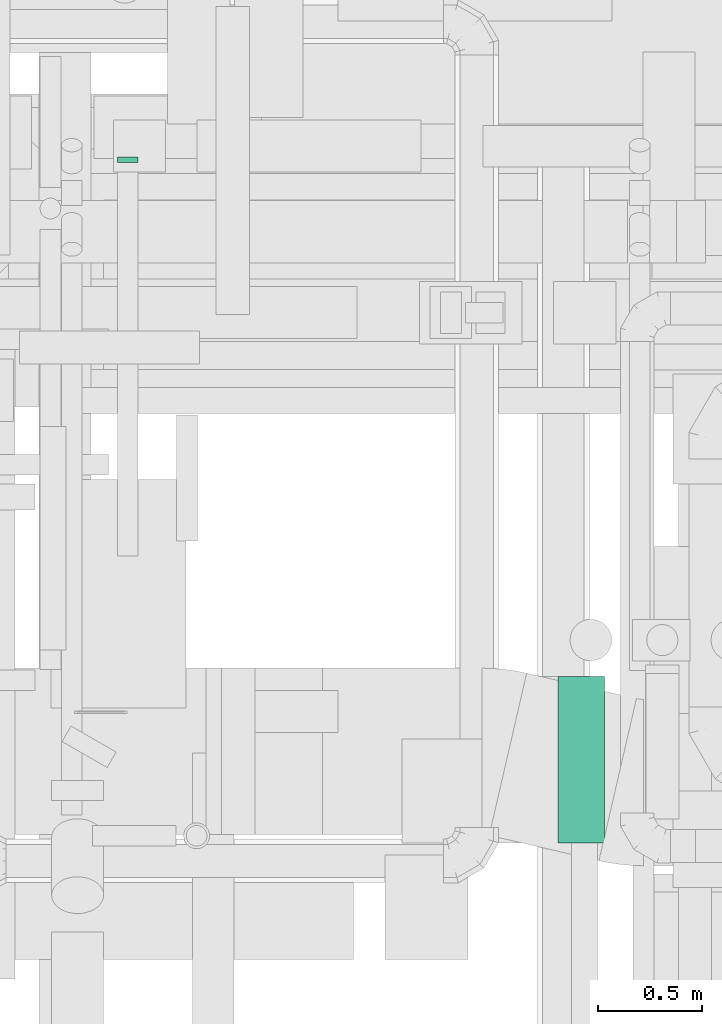
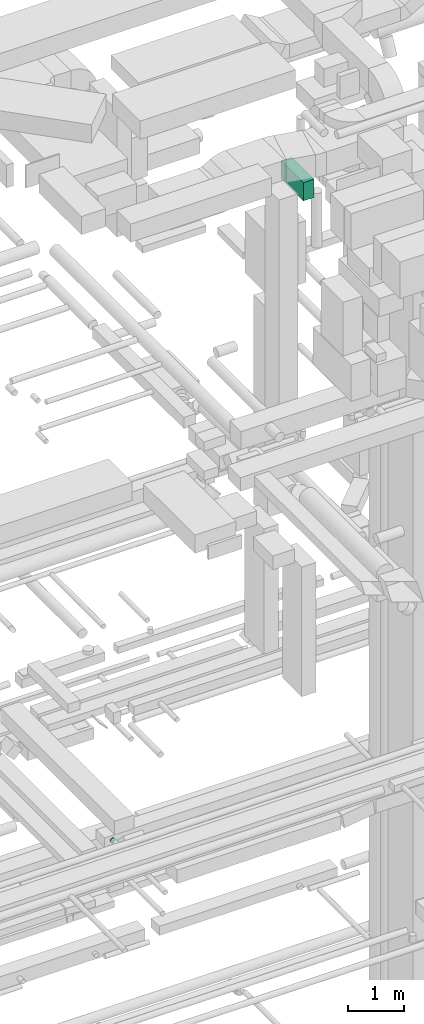
# One storey, part 175 of 337: 1 flow fitting, 1 flow segment.
"""IFC2X3 building model written with IfcOpenShell, lengths in millimetres."""

from ifc_helpers import new_model, entity, si_unit, converted_unit, derived_unit, direction, frame, origin, origin_2d_with_axis, place, context, subcontext, project, spatial, rectangle, extrude, faceted_brep, source, transform, mapped, material, type_object, type_shapes, element, save


model = new_model("IFC2X3")

# Units and contexts
model_context = context("Model", 3, precision=0.01, world=origin(), true_north=direction((6.12303176911189e-17, 1.0)))
body_context = subcontext(model_context, "Body", "Model", "MODEL_VIEW")
ifc_project = project(units=[si_unit("LENGTHUNIT", "METRE", prefix="MILLI"), si_unit("AREAUNIT", "SQUARE_METRE"), si_unit("VOLUMEUNIT", "CUBIC_METRE"), converted_unit("PLANEANGLEUNIT", "DEGREE", entity("IfcRatioMeasure", 0.0174532925199433), si_unit("PLANEANGLEUNIT", "RADIAN"), dimensions=[0, 0, 0, 0, 0, 0, 0]), si_unit("MASSUNIT", "GRAM", prefix="KILO"), derived_unit("MASSDENSITYUNIT", [(si_unit("MASSUNIT", "GRAM", prefix="KILO"), 1), (si_unit("LENGTHUNIT", "METRE"), -3)]), derived_unit("MOMENTOFINERTIAUNIT", [(si_unit("LENGTHUNIT", "METRE"), 4)]), si_unit("TIMEUNIT", "SECOND"), si_unit("FREQUENCYUNIT", "HERTZ"), si_unit("THERMODYNAMICTEMPERATUREUNIT", "DEGREE_CELSIUS"), derived_unit("THERMALTRANSMITTANCEUNIT", [(si_unit("MASSUNIT", "GRAM", prefix="KILO"), 1), (si_unit("THERMODYNAMICTEMPERATUREUNIT", "KELVIN"), -1), (si_unit("TIMEUNIT", "SECOND"), -3)]), derived_unit("VOLUMETRICFLOWRATEUNIT", [(si_unit("LENGTHUNIT", "METRE"), 3), (si_unit("TIMEUNIT", "SECOND"), -1)]), derived_unit("MASSFLOWRATEUNIT", [(si_unit("MASSUNIT", "GRAM", prefix="KILO"), 1), (si_unit("TIMEUNIT", "SECOND"), -1)]), derived_unit("ROTATIONALFREQUENCYUNIT", [(si_unit("TIMEUNIT", "SECOND"), -1)]), si_unit("ELECTRICCURRENTUNIT", "AMPERE"), si_unit("ELECTRICVOLTAGEUNIT", "VOLT"), si_unit("POWERUNIT", "WATT"), si_unit("FORCEUNIT", "NEWTON", prefix="KILO"), si_unit("ILLUMINANCEUNIT", "LUX"), si_unit("LUMINOUSFLUXUNIT", "LUMEN"), si_unit("LUMINOUSINTENSITYUNIT", "CANDELA"), derived_unit("USERDEFINED", [(si_unit("MASSUNIT", "GRAM", prefix="KILO"), -1), (si_unit("LENGTHUNIT", "METRE"), -2), (si_unit("TIMEUNIT", "SECOND"), 3), (si_unit("LUMINOUSFLUXUNIT", "LUMEN"), 1)]), derived_unit("LINEARVELOCITYUNIT", [(si_unit("LENGTHUNIT", "METRE"), 1), (si_unit("TIMEUNIT", "SECOND"), -1)]), si_unit("PRESSUREUNIT", "PASCAL"), derived_unit("USERDEFINED", [(si_unit("LENGTHUNIT", "METRE"), -2), (si_unit("MASSUNIT", "GRAM", prefix="KILO"), 1), (si_unit("TIMEUNIT", "SECOND"), -2)]), derived_unit("LINEARFORCEUNIT", [(si_unit("MASSUNIT", "GRAM", prefix="KILO"), 1), (si_unit("LENGTHUNIT", "METRE"), 1), (si_unit("TIMEUNIT", "SECOND"), -2), (si_unit("LENGTHUNIT", "METRE"), -1)]), derived_unit("PLANARFORCEUNIT", [(si_unit("MASSUNIT", "GRAM", prefix="KILO"), 1), (si_unit("LENGTHUNIT", "METRE"), 1), (si_unit("TIMEUNIT", "SECOND"), -2), (si_unit("LENGTHUNIT", "METRE"), -2)])], contexts=[model_context])

# Site, building, storey
site_placement = place(None, origin())
site = spatial("IfcSite", under=ifc_project, at=site_placement, CompositionType="ELEMENT")
building_placement = place(site_placement, origin())
building = spatial("IfcBuilding", under=site, at=building_placement, CompositionType="ELEMENT")
storey_placement = place(building_placement, origin())
storey = spatial("IfcBuildingStorey", under=building, at=storey_placement, CompositionType="ELEMENT", Elevation=0.0)

# Flow segment
duct_segment_type = type_object("IfcDuctSegmentType", PredefinedType="NOTDEFINED")
flow_segment_placement = place(storey_placement, frame((42830.17, 11999.85, 30650.0)))
element("IfcFlowSegment", 1, at=flow_segment_placement, inside=storey, type_object=duct_segment_type, context=body_context, shape_type="SweptSolid", body=[
    extrude(rectangle(XDim=222.693139999963, YDim=800.0, at=origin_2d_with_axis()), frame((111.35, 400.0, 0.0)), (0.0, 0.0, 1.0), 399.999999999996),
])

# Flow fitting
ifc_material = material()
duct_fitting_type = type_object("IfcDuctFittingType", PredefinedType="NOTDEFINED", material=ifc_material)
shared_shape = source(origin(), body_context, "Body", "Brep", [
    faceted_brep([(20.0, 0.0, -50.0), (20.0, 12.94, -48.3), (20.0, 25.0, -43.3), (20.0, 35.36, -35.36), (20.0, 43.3, -25.0), (20.0, 48.3, -12.94), (20.0, 50.0, 0.0), (20.0, 48.3, 12.94), (20.0, 43.3, 25.0), (20.0, 35.36, 35.36), (20.0, 25.0, 43.3), (20.0, 12.94, 48.3), (20.0, 0.0, 50.0), (20.0, -12.94, 48.3), (20.0, -25.0, 43.3), (20.0, -35.36, 35.36), (20.0, -43.3, 25.0), (20.0, -48.3, 12.94), (20.0, -50.0, 0.0), (20.0, -48.3, -12.94), (20.0, -43.3, -25.0), (20.0, -35.36, -35.36), (20.0, -25.0, -43.3), (20.0, -12.94, -48.3), (0.0, 0.0, 50.0), (-6.1, 0.0, 50.0), (-6.1, -12.94, 48.3), (0.0, -12.94, 48.3), (-6.1, -25.0, 43.3), (0.0, -25.0, 43.3), (0.0, -35.36, 35.36), (-6.1, -35.36, 35.36), (0.0, -43.3, 25.0), (-6.1, -43.3, 25.0), (-6.1, -48.3, 12.94), (0.0, -48.3, 12.94), (-6.1, -50.0, 0.0), (0.0, -50.0, 0.0), (-6.1, -48.3, -12.94), (0.0, -48.3, -12.94), (-6.1, -43.3, -25.0), (0.0, -43.3, -25.0), (0.0, -35.36, -35.36), (-6.1, -35.36, -35.36), (0.0, -25.0, -43.3), (-6.1, -25.0, -43.3), (-6.1, -12.94, -48.3), (0.0, -12.94, -48.3), (-6.1, 0.0, -50.0), (0.0, 0.0, -50.0), (-6.1, 12.94, -48.3), (0.0, 12.94, -48.3), (-6.1, 25.0, -43.3), (0.0, 25.0, -43.3), (0.0, 35.36, -35.36), (-6.1, 35.36, -35.36), (0.0, 43.3, -25.0), (-6.1, 43.3, -25.0), (-6.1, 48.3, -12.94), (0.0, 48.3, -12.94), (-6.1, 50.0, 0.0), (0.0, 50.0, 0.0), (-6.1, 48.3, 12.94), (0.0, 48.3, 12.94), (-6.1, 43.3, 25.0), (0.0, 43.3, 25.0), (0.0, 35.36, 35.36), (-6.1, 35.36, 35.36), (0.0, 25.0, 43.3), (-6.1, 25.0, 43.3), (-6.1, 12.94, 48.3), (0.0, 12.94, 48.3)], [[[0, 1, 2, 3, 4, 5, 6, 7, 8, 9, 10, 11, 12, 13, 14, 15, 16, 17, 18, 19, 20, 21, 22, 23]], [[13, 12, 24, 25, 26, 27]], [[14, 13, 27, 26, 28, 29]], [[30, 15, 14, 29, 28, 31]], [[17, 16, 32, 33, 34, 35]], [[18, 17, 35, 34, 36, 37]], [[32, 16, 15, 30, 31, 33]], [[19, 18, 37, 36, 38, 39]], [[20, 19, 39, 38, 40, 41]], [[42, 21, 20, 41, 40, 43]], [[23, 22, 44, 45, 46, 47]], [[0, 23, 47, 46, 48, 49]], [[44, 22, 21, 42, 43, 45]], [[1, 0, 49, 48, 50, 51]], [[2, 1, 51, 50, 52, 53]], [[54, 3, 2, 53, 52, 55]], [[5, 4, 56, 57, 58, 59]], [[6, 5, 59, 58, 60, 61]], [[56, 4, 3, 54, 55, 57]], [[7, 6, 61, 60, 62, 63]], [[8, 7, 63, 62, 64, 65]], [[66, 9, 8, 65, 64, 67]], [[11, 10, 68, 69, 70, 71]], [[12, 11, 71, 70, 25, 24]], [[68, 10, 9, 66, 67, 69]], [[46, 45, 43, 40, 38, 36, 34, 33, 31, 28, 26, 25, 70, 69, 67, 64, 62, 60, 58, 57, 55, 52, 50, 48]]]),
])
type_shapes(duct_fitting_type, [shared_shape])
flow_fitting_placement = place(storey_placement, frame((40761.7, 15290.0, 15350.0), z_axis=(0.0, 0.0, -1.0), x_axis=(0.0, -1.0, 0.0)))
element("IfcFlowFitting", 2, at=flow_fitting_placement, inside=storey, type_object=duct_fitting_type, material=ifc_material, context=body_context, shape_type="MappedRepresentation", body=[
    mapped(shared_shape, transform((0.0, 0.0, 0.0), scale=1.0)),
])

save(model, "model.ifc")
